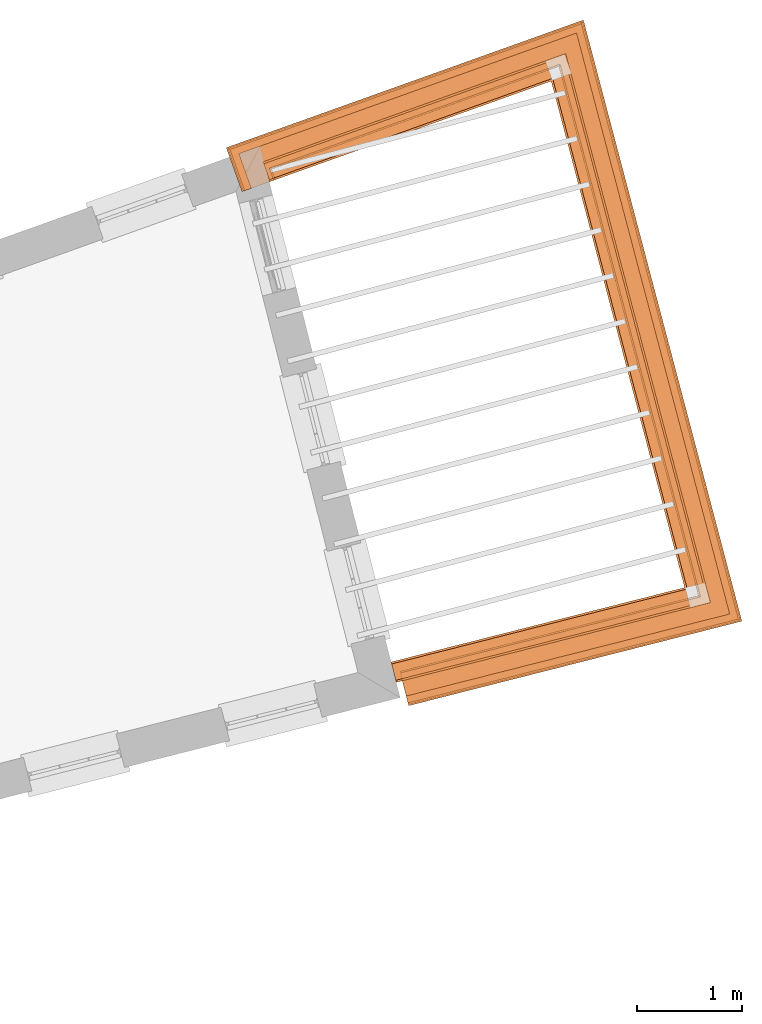
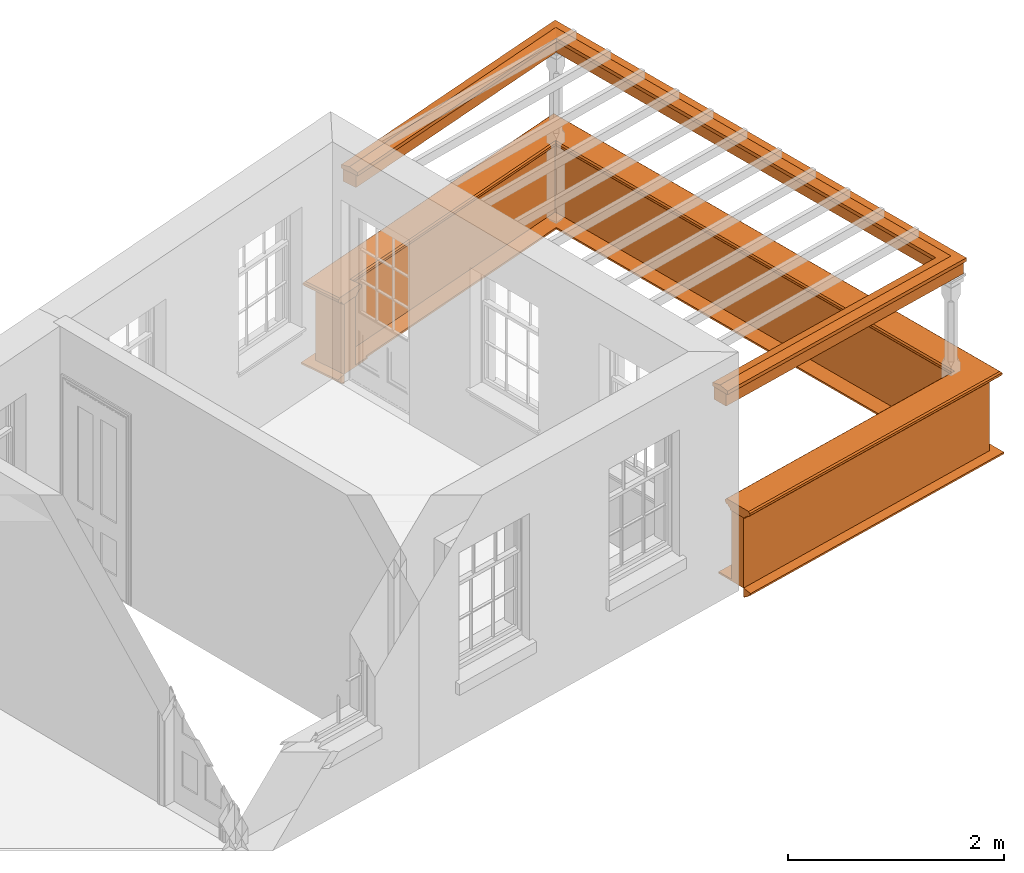
# One storey, part 9 of 10: 5 proxies.
"""IFC2X3 building model written with IfcOpenShell, lengths in metres."""

import ifcopenshell
import ifcopenshell.guid

model = None  # the IFC model being written
_history = None  # IfcOwnerHistory: only IFC2X3 demands one
_inside = {}  # id of a spatial element -> (the spatial element, [elements in it])
_under = {}  # id of a project, library or spatial element -> (it, [spatial elements below it])
_declared = {}  # id of a project -> (the project, [libraries it declares])
_typed = {}  # id of a type object -> (the type object, [elements of that type])
_made_of = {}  # id of a material, layer set ... -> (it, [elements and type objects made of it])


def new_model(schema):
    """Start an empty IFC model of exactly this schema.

    Asked for "IFC4X3", IfcOpenShell would pick the latest addendum, in which some entities
    have other attributes; the version numbers below select the first issue.
    IFC2X3 requires an IfcOwnerHistory on every rooted entity: one is made here for all.
    """
    global model, _history
    if schema == "IFC4X3":
        model = ifcopenshell.file(schema_version=(4, 3, 0, 0))
    else:
        model = ifcopenshell.file(schema=schema)
    _inside.clear()
    _under.clear()
    _declared.clear()
    _typed.clear()
    _made_of.clear()
    _history = None
    if model.schema == "IFC2X3":
        org = make("IfcOrganization", Name="unknown")
        user = make(
            "IfcPersonAndOrganization",
            ThePerson=make("IfcPerson", FamilyName="unknown"),
            TheOrganization=org,
        )
        app = make(
            "IfcApplication",
            ApplicationDeveloper=org,
            Version="unknown",
            ApplicationFullName="unknown",
            ApplicationIdentifier="unknown",
        )
        _history = make(
            "IfcOwnerHistory",
            OwningUser=user,
            OwningApplication=app,
            ChangeAction="ADDED",
            CreationDate=0,
        )
    return model


def make(cls, **values):
    """One entity of the class cls with the attributes given. An attribute that is None is left unset."""
    return model.create_entity(
        cls, **{name: value for name, value in values.items() if value is not None}
    )


def entity(cls, *values):
    """Any entity or typed value of the class cls, its attributes in the order of the schema. None: left unset."""
    e = model.create_entity(cls)
    for i, value in enumerate(values):
        if value is not None:
            e[i] = value
    return e


def rooted(cls, **values):
    """An entity with a GlobalId (a new one), such as an element, a storey or a relation."""
    return make(cls, GlobalId=ifcopenshell.guid.new(), OwnerHistory=_history, **values)


def si_unit(unit_type, name, prefix=None):
    """IfcSIUnit, for example si_unit("LENGTHUNIT", "METRE", prefix="MILLI")."""
    return make("IfcSIUnit", UnitType=unit_type, Prefix=prefix, Name=name)


def assignment(units):
    """IfcUnitAssignment: the units of a project."""
    return None if units is None else make("IfcUnitAssignment", Units=units)


def point(xyz):
    """IfcCartesianPoint."""
    return None if xyz is None else make("IfcCartesianPoint", Coordinates=xyz)


def direction(xyz):
    """IfcDirection."""
    return None if xyz is None else make("IfcDirection", DirectionRatios=xyz)


def frame(location, z_axis=None, x_axis=None):
    """IfcAxis2Placement3D, a coordinate frame: its origin and axes. An axis left out is left unset."""
    return make(
        "IfcAxis2Placement3D",
        Location=point(location),
        Axis=direction(z_axis),
        RefDirection=direction(x_axis),
    )


def origin():
    """The frame at (0, 0, 0) with its axes left unset."""
    return frame((0.0, 0.0, 0.0))


def place(relative_to, where):
    """IfcLocalPlacement: puts the frame where relative to a parent placement (None: the world)."""
    return make(
        "IfcLocalPlacement", PlacementRelTo=relative_to, RelativePlacement=where
    )


def context(
    kind, dimensions, precision=None, world=None, true_north=None, identifier=None
):
    """IfcGeometricRepresentationContext, for example the 3D "Model" context."""
    return make(
        "IfcGeometricRepresentationContext",
        ContextIdentifier=identifier,
        ContextType=kind,
        CoordinateSpaceDimension=dimensions,
        Precision=precision,
        WorldCoordinateSystem=world,
        TrueNorth=true_north,
    )


def subcontext(parent, identifier, kind, view, scale=None):
    """IfcGeometricRepresentationSubContext, for example "Body" below "Model"."""
    return make(
        "IfcGeometricRepresentationSubContext",
        ContextIdentifier=identifier,
        ContextType=kind,
        ParentContext=parent,
        TargetScale=scale,
        TargetView=view,
    )


def project(units=None, contexts=None):
    """IfcProject with its units and contexts."""
    return rooted(
        "IfcProject",
        Name="project",
        RepresentationContexts=contexts,
        UnitsInContext=assignment(units),
    )


def spatial(cls, under=None, at=None, **own):
    """A site, building, storey or space (cls), placed at a placement, below another one or the project."""
    s = rooted(cls, ObjectPlacement=at, **own)
    if under is not None:
        _under.setdefault(under.id(), (under, []))[1].append(s)
    return s


def shape(context_of_items, identifier, shape_type, items):
    """IfcShapeRepresentation: the items that make up one representation, for example the "Body"."""
    return make(
        "IfcShapeRepresentation",
        ContextOfItems=context_of_items,
        RepresentationIdentifier=identifier,
        RepresentationType=shape_type,
        Items=items,
    )


def made_of(thing, what):
    """Note that an element or type object is made of a material, layer set ...; save() writes the relation."""
    if what is not None:
        _made_of.setdefault(what.id(), (what, []))[1].append(thing)
    return thing


def element(
    cls,
    number,
    at=None,
    inside=None,
    cuts=None,
    type_object=None,
    material=None,
    context=None,
    identifier="Body",
    shape_type=None,
    held_by="IfcProductDefinitionShape",
    body=None,
    shapes=None,
    **own,
):
    """One element of the class cls, such as IfcWall. Its Tag is "e" and its number.

    at: its placement. inside: the storey or other place that contains it. cuts: it is an
    opening in that element (IfcRelVoidsElement). A single representation is given by context,
    identifier, shape_type and body (its items); several are given by shapes. held_by: the class
    of the entity that holds the representations. save() writes the other relations.
    """
    e = rooted(cls, Tag="e%d" % number, ObjectPlacement=at, **own)
    if body is not None:
        shapes = [shape(context, identifier, shape_type, body)]
    if shapes is not None:
        e.Representation = make(held_by, Representations=shapes)
    if inside is not None:
        _inside.setdefault(inside.id(), (inside, []))[1].append(e)
    if cuts is not None:
        rooted(
            "IfcRelVoidsElement", RelatingBuildingElement=cuts, RelatedOpeningElement=e
        )
    if type_object is not None:
        _typed.setdefault(type_object.id(), (type_object, []))[1].append(e)
    return made_of(e, material)


def aggregate(whole, parts):
    """IfcRelAggregates: a whole, such as a stair, and the parts it consists of."""
    return rooted("IfcRelAggregates", RelatingObject=whole, RelatedObjects=parts)


def save(model, path):
    """Write the relations noted so far, then the file.

    IfcRelAggregates (storeys below a building ...), IfcRelContainedInSpatialStructure (elements
    in a storey), IfcRelDefinesByType, IfcRelAssociatesMaterial and IfcRelDeclares: one each for
    every whole, place, type object, material and project.
    """
    for whole, parts in _under.values():
        aggregate(whole, parts)
    for where, things in _inside.values():
        rooted(
            "IfcRelContainedInSpatialStructure",
            RelatedElements=things,
            RelatingStructure=where,
        )
    for kind, things in _typed.values():
        rooted("IfcRelDefinesByType", RelatedObjects=things, RelatingType=kind)
    for what, things in _made_of.values():
        rooted("IfcRelAssociatesMaterial", RelatedObjects=things, RelatingMaterial=what)
    for by, libraries in _declared.values():
        rooted("IfcRelDeclares", RelatingContext=by, RelatedDefinitions=libraries)
    model.write(path)


model = new_model("IFC2X3")

# Units and contexts
model_context = context("Model", 3, world=origin())
body_context = subcontext(model_context, "Body", "Model", "MODEL_VIEW")
ifc_project = project(units=[si_unit("PLANEANGLEUNIT", "RADIAN"), si_unit("MASSUNIT", "GRAM", prefix="KILO"), si_unit("FORCEUNIT", "NEWTON", prefix="KILO"), si_unit("LENGTHUNIT", "METRE")], contexts=[model_context])

# Site, building, storey
site_placement = place(None, origin())
site = spatial("IfcSite", under=ifc_project, at=site_placement, CompositionType="ELEMENT")
building_placement = place(None, origin())
building = spatial("IfcBuilding", under=site, at=building_placement, Name="Building plot-13", CompositionType="ELEMENT")
storey_placement = place(None, frame((0.0, 0.0, 9.55)))
storey = spatial("IfcBuildingStorey", under=building, at=storey_placement, Name="Floor 2", CompositionType="ELEMENT", Elevation=9.55)

# Proxies
proxy_1_placement = place(storey_placement, origin())
axis2_placement3_d_1 = entity("IfcAxis2Placement3D", entity("IfcCartesianPoint", [0.0, 0.0, 0.0]))
element("IfcBuildingElementProxy", 1, at=proxy_1_placement, inside=storey, Name="parapet", CompositionType="ELEMENT", context=body_context, shape_type="SweptSolid", held_by="IfcProductRepresentation", body=[
    entity("IfcSurfaceCurveSweptAreaSolid", entity("IfcArbitraryClosedProfileDef", "AREA", None, entity("IfcPolyline", [entity("IfcCartesianPoint", [0.0, 0.25]), entity("IfcCartesianPoint", [0.795, 0.25]), entity("IfcCartesianPoint", [0.795, 0.09]), entity("IfcCartesianPoint", [0.02, 0.09]), entity("IfcCartesianPoint", [0.02, -0.08]), entity("IfcCartesianPoint", [0.0, -0.08]), entity("IfcCartesianPoint", [0.0, 0.25])])), axis2_placement3_d_1, entity("IfcPolyline", [entity("IfcCartesianPoint", [77.2422700413002, 46.4713798714146]), entity("IfcCartesianPoint", [80.0797172542298, 47.1910334064089]), entity("IfcCartesianPoint", [78.7542279289787, 52.2190976723902]), entity("IfcCartesianPoint", [76.0301010151658, 51.2450277183192]), entity("IfcCartesianPoint", [76.063770442349, 51.150866316072])]), 0.0, 1.0, entity("IfcPlane", axis2_placement3_d_1)),
])
proxy_2_placement = place(storey_placement, origin())
axis2_placement3_d_2 = entity("IfcAxis2Placement3D", entity("IfcCartesianPoint", [0.0, 0.0, 0.0]))
element("IfcBuildingElementProxy", 2, at=proxy_2_placement, inside=storey, Name="parapet", CompositionType="ELEMENT", context=body_context, shape_type="SweptSolid", held_by="IfcProductRepresentation", body=[
    entity("IfcSurfaceCurveSweptAreaSolid", entity("IfcArbitraryClosedProfileDef", "AREA", None, entity("IfcPolyline", [entity("IfcCartesianPoint", [0.795, 0.265]), entity("IfcCartesianPoint", [0.807, 0.268]), entity("IfcCartesianPoint", [0.816, 0.274]), entity("IfcCartesianPoint", [0.822, 0.283]), entity("IfcCartesianPoint", [0.825, 0.295]), entity("IfcCartesianPoint", [0.84, 0.295]), entity("IfcCartesianPoint", [0.84, 0.305]), entity("IfcCartesianPoint", [0.842, 0.317]), entity("IfcCartesianPoint", [0.849, 0.326]), entity("IfcCartesianPoint", [0.858, 0.333]), entity("IfcCartesianPoint", [0.87, 0.335]), entity("IfcCartesianPoint", [0.882, 0.333]), entity("IfcCartesianPoint", [0.891, 0.326]), entity("IfcCartesianPoint", [0.898, 0.317]), entity("IfcCartesianPoint", [0.9, 0.305]), entity("IfcCartesianPoint", [0.9, 0.035]), entity("IfcCartesianPoint", [0.898, 0.023]), entity("IfcCartesianPoint", [0.891, 0.014]), entity("IfcCartesianPoint", [0.882, 0.007]), entity("IfcCartesianPoint", [0.87, 0.005]), entity("IfcCartesianPoint", [0.858, 0.007]), entity("IfcCartesianPoint", [0.849, 0.014]), entity("IfcCartesianPoint", [0.842, 0.023]), entity("IfcCartesianPoint", [0.84, 0.035]), entity("IfcCartesianPoint", [0.84, 0.045]), entity("IfcCartesianPoint", [0.825, 0.045]), entity("IfcCartesianPoint", [0.822, 0.057]), entity("IfcCartesianPoint", [0.816, 0.066]), entity("IfcCartesianPoint", [0.807, 0.072]), entity("IfcCartesianPoint", [0.795, 0.075]), entity("IfcCartesianPoint", [0.795, 0.265])])), axis2_placement3_d_2, entity("IfcPolyline", [entity("IfcCartesianPoint", [77.2422700413002, 46.4713798714146]), entity("IfcCartesianPoint", [80.0797172542298, 47.1910334064089]), entity("IfcCartesianPoint", [78.7542279289787, 52.2190976723902]), entity("IfcCartesianPoint", [76.0301010151658, 51.2450277183192]), entity("IfcCartesianPoint", [76.063770442349, 51.150866316072])]), 0.0, 1.0, entity("IfcPlane", axis2_placement3_d_2)),
])
proxy_3_placement = place(storey_placement, origin())
axis2_placement3_d_3 = entity("IfcAxis2Placement3D", entity("IfcCartesianPoint", [0.0, 0.0, 0.0]))
element("IfcBuildingElementProxy", 3, at=proxy_3_placement, inside=storey, Name="parapet", CompositionType="ELEMENT", context=body_context, shape_type="SweptSolid", held_by="IfcProductRepresentation", body=[
    entity("IfcSurfaceCurveSweptAreaSolid", entity("IfcArbitraryClosedProfileDef", "AREA", None, entity("IfcPolyline", [entity("IfcCartesianPoint", [-0.1, 0.25]), entity("IfcCartesianPoint", [-0.1, 0.265]), entity("IfcCartesianPoint", [-0.085, 0.265]), entity("IfcCartesianPoint", [-0.084, 0.278]), entity("IfcCartesianPoint", [-0.081, 0.289]), entity("IfcCartesianPoint", [-0.074, 0.301]), entity("IfcCartesianPoint", [-0.065, 0.309]), entity("IfcCartesianPoint", [-0.055, 0.315]), entity("IfcCartesianPoint", [-0.044, 0.324]), entity("IfcCartesianPoint", [-0.038, 0.334]), entity("IfcCartesianPoint", [-0.035, 0.345]), entity("IfcCartesianPoint", [-0.015, 0.345]), entity("IfcCartesianPoint", [0.0, 0.25]), entity("IfcCartesianPoint", [-0.1, 0.25])])), axis2_placement3_d_3, entity("IfcPolyline", [entity("IfcCartesianPoint", [77.2422700413002, 46.4713798714146]), entity("IfcCartesianPoint", [80.0797172542298, 47.1910334064089]), entity("IfcCartesianPoint", [78.7542279289787, 52.2190976723902]), entity("IfcCartesianPoint", [76.0301010151658, 51.2450277183192]), entity("IfcCartesianPoint", [76.063770442349, 51.150866316072])]), 0.0, 1.0, entity("IfcPlane", axis2_placement3_d_3)),
])
proxy_4_placement = place(storey_placement, frame((0.0, 0.0, 2.7)))
axis2_placement3_d_4 = entity("IfcAxis2Placement3D", entity("IfcCartesianPoint", [0.0, 0.0, 0.0]))
element("IfcBuildingElementProxy", 4, at=proxy_4_placement, inside=storey, Name="pergola beam", CompositionType="ELEMENT", context=body_context, shape_type="SweptSolid", held_by="IfcProductRepresentation", body=[
    entity("IfcSurfaceCurveSweptAreaSolid", entity("IfcArbitraryClosedProfileDef", "AREA", None, entity("IfcPolyline", [entity("IfcCartesianPoint", [-0.7, -0.08]), entity("IfcCartesianPoint", [-0.7, 0.08]), entity("IfcCartesianPoint", [-0.56, 0.08]), entity("IfcCartesianPoint", [-0.56, -0.08]), entity("IfcCartesianPoint", [-0.7, -0.08])])), axis2_placement3_d_4, entity("IfcPolyline", [entity("IfcCartesianPoint", [77.1841114645947, 46.4566292797117]), entity("IfcCartesianPoint", [80.0797172542298, 47.1910334064089]), entity("IfcCartesianPoint", [78.7542279289787, 52.2190976723902]), entity("IfcCartesianPoint", [75.9736041738175, 51.2248260620093])]), 0.0, 1.0, entity("IfcPlane", axis2_placement3_d_4)),
])
proxy_5_placement = place(storey_placement, frame((0.0, 0.0, 2.7)))
axis2_placement3_d_5 = entity("IfcAxis2Placement3D", entity("IfcCartesianPoint", [0.0, 0.0, 0.0]))
element("IfcBuildingElementProxy", 5, at=proxy_5_placement, inside=storey, Name="pergola beam", CompositionType="ELEMENT", context=body_context, shape_type="SweptSolid", held_by="IfcProductRepresentation", body=[
    entity("IfcSurfaceCurveSweptAreaSolid", entity("IfcArbitraryClosedProfileDef", "AREA", None, entity("IfcPolyline", [entity("IfcCartesianPoint", [-0.5, 0.0]), entity("IfcCartesianPoint", [-0.52, -0.1]), entity("IfcCartesianPoint", [-0.56, -0.1]), entity("IfcCartesianPoint", [-0.56, 0.1]), entity("IfcCartesianPoint", [-0.52, 0.1]), entity("IfcCartesianPoint", [-0.5, 0.0])])), axis2_placement3_d_5, entity("IfcPolyline", [entity("IfcCartesianPoint", [77.1841114645947, 46.4566292797117]), entity("IfcCartesianPoint", [80.0797172542298, 47.1910334064089]), entity("IfcCartesianPoint", [78.7542279289787, 52.2190976723902]), entity("IfcCartesianPoint", [75.9736041738175, 51.2248260620093])]), 0.0, 1.0, entity("IfcPlane", axis2_placement3_d_5)),
])

save(model, "model.ifc")
